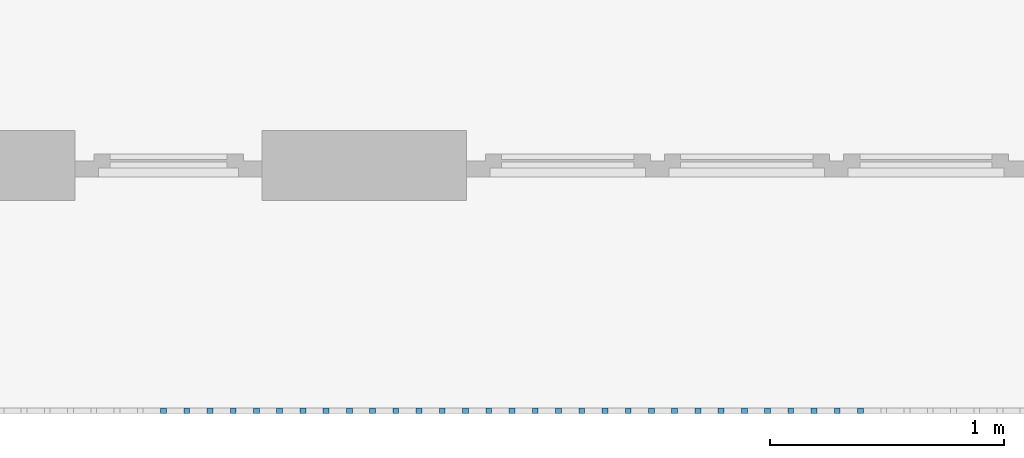
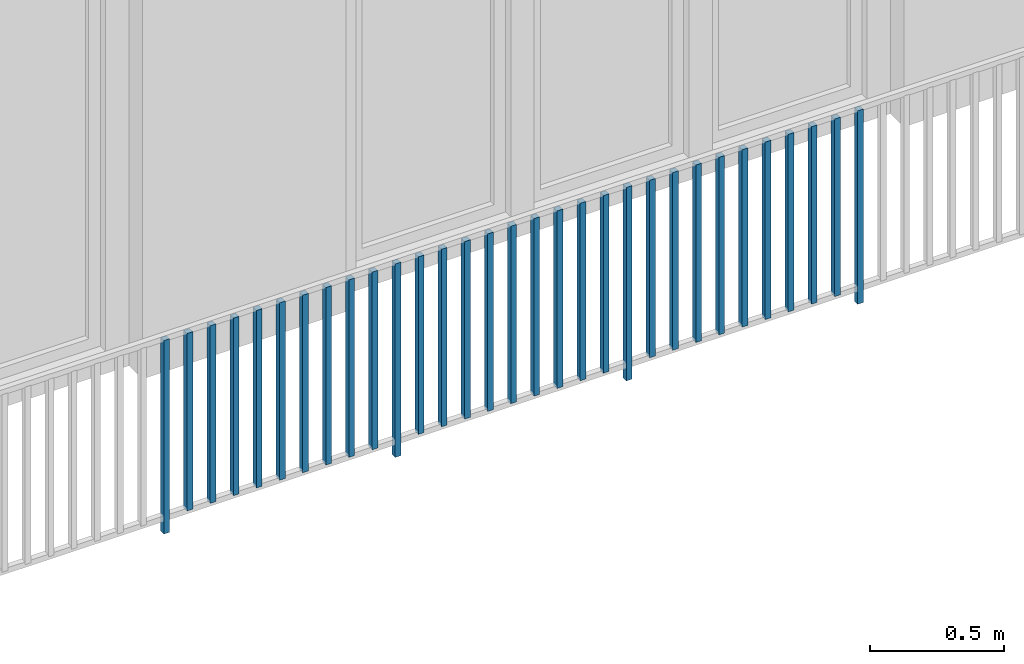
# One storey, part 30 of 48: 31 building element parts, 1 element without a shape of its own.
"""IFC4 building model written with IfcOpenShell, lengths in metres."""

import ifcopenshell
import ifcopenshell.guid

model = None  # the IFC model being written
_history = None  # IfcOwnerHistory: only IFC2X3 demands one
_inside = {}  # id of a spatial element -> (the spatial element, [elements in it])
_under = {}  # id of a project, library or spatial element -> (it, [spatial elements below it])
_declared = {}  # id of a project -> (the project, [libraries it declares])
_typed = {}  # id of a type object -> (the type object, [elements of that type])
_made_of = {}  # id of a material, layer set ... -> (it, [elements and type objects made of it])


def new_model(schema):
    """Start an empty IFC model of exactly this schema.

    Asked for "IFC4X3", IfcOpenShell would pick the latest addendum, in which some entities
    have other attributes; the version numbers below select the first issue.
    IFC2X3 requires an IfcOwnerHistory on every rooted entity: one is made here for all.
    """
    global model, _history
    if schema == "IFC4X3":
        model = ifcopenshell.file(schema_version=(4, 3, 0, 0))
    else:
        model = ifcopenshell.file(schema=schema)
    _inside.clear()
    _under.clear()
    _declared.clear()
    _typed.clear()
    _made_of.clear()
    _history = None
    if model.schema == "IFC2X3":
        org = make("IfcOrganization", Name="unknown")
        user = make(
            "IfcPersonAndOrganization",
            ThePerson=make("IfcPerson", FamilyName="unknown"),
            TheOrganization=org,
        )
        app = make(
            "IfcApplication",
            ApplicationDeveloper=org,
            Version="unknown",
            ApplicationFullName="unknown",
            ApplicationIdentifier="unknown",
        )
        _history = make(
            "IfcOwnerHistory",
            OwningUser=user,
            OwningApplication=app,
            ChangeAction="ADDED",
            CreationDate=0,
        )
    return model


def make(cls, **values):
    """One entity of the class cls with the attributes given. An attribute that is None is left unset."""
    return model.create_entity(
        cls, **{name: value for name, value in values.items() if value is not None}
    )


def entity(cls, *values):
    """Any entity or typed value of the class cls, its attributes in the order of the schema. None: left unset."""
    e = model.create_entity(cls)
    for i, value in enumerate(values):
        if value is not None:
            e[i] = value
    return e


def rooted(cls, **values):
    """An entity with a GlobalId (a new one), such as an element, a storey or a relation."""
    return make(cls, GlobalId=ifcopenshell.guid.new(), OwnerHistory=_history, **values)


def si_unit(unit_type, name, prefix=None):
    """IfcSIUnit, for example si_unit("LENGTHUNIT", "METRE", prefix="MILLI")."""
    return make("IfcSIUnit", UnitType=unit_type, Prefix=prefix, Name=name)


def converted_unit(unit_type, name, factor, base, dimensions=None, offset=None):
    """IfcConversionBasedUnit, such as the inch: factor (a typed value) times the base unit."""
    return make(
        "IfcConversionBasedUnit"
        if offset is None
        else "IfcConversionBasedUnitWithOffset",
        ConversionOffset=offset,
        Dimensions=None
        if dimensions is None
        else entity("IfcDimensionalExponents", *dimensions),
        UnitType=unit_type,
        Name=name,
        ConversionFactor=make(
            "IfcMeasureWithUnit", ValueComponent=factor, UnitComponent=base
        ),
    )


def derived_unit(unit_type, elements):
    """IfcDerivedUnit: a product of units, each with its exponent."""
    return make(
        "IfcDerivedUnit",
        Elements=[
            make("IfcDerivedUnitElement", Unit=unit, Exponent=power)
            for unit, power in elements
        ],
        UnitType=unit_type,
    )


def assignment(units):
    """IfcUnitAssignment: the units of a project."""
    return None if units is None else make("IfcUnitAssignment", Units=units)


def point(xyz):
    """IfcCartesianPoint."""
    return None if xyz is None else make("IfcCartesianPoint", Coordinates=xyz)


def direction(xyz):
    """IfcDirection."""
    return None if xyz is None else make("IfcDirection", DirectionRatios=xyz)


def frame(location, z_axis=None, x_axis=None):
    """IfcAxis2Placement3D, a coordinate frame: its origin and axes. An axis left out is left unset."""
    return make(
        "IfcAxis2Placement3D",
        Location=point(location),
        Axis=direction(z_axis),
        RefDirection=direction(x_axis),
    )


def origin_with_axes():
    """The frame at (0, 0, 0) with the z axis (0, 0, 1) and the x axis (1, 0, 0) written out."""
    return frame((0.0, 0.0, 0.0), z_axis=(0.0, 0.0, 1.0), x_axis=(1.0, 0.0, 0.0))


def place(relative_to, where):
    """IfcLocalPlacement: puts the frame where relative to a parent placement (None: the world)."""
    return make(
        "IfcLocalPlacement", PlacementRelTo=relative_to, RelativePlacement=where
    )


def context(
    kind, dimensions, precision=None, world=None, true_north=None, identifier=None
):
    """IfcGeometricRepresentationContext, for example the 3D "Model" context."""
    return make(
        "IfcGeometricRepresentationContext",
        ContextIdentifier=identifier,
        ContextType=kind,
        CoordinateSpaceDimension=dimensions,
        Precision=precision,
        WorldCoordinateSystem=world,
        TrueNorth=true_north,
    )


def subcontext(parent, identifier, kind, view, scale=None):
    """IfcGeometricRepresentationSubContext, for example "Body" below "Model"."""
    return make(
        "IfcGeometricRepresentationSubContext",
        ContextIdentifier=identifier,
        ContextType=kind,
        ParentContext=parent,
        TargetScale=scale,
        TargetView=view,
    )


def project(units=None, contexts=None):
    """IfcProject with its units and contexts."""
    return rooted(
        "IfcProject",
        Name="project",
        RepresentationContexts=contexts,
        UnitsInContext=assignment(units),
    )


def spatial(cls, under=None, at=None, **own):
    """A site, building, storey or space (cls), placed at a placement, below another one or the project."""
    s = rooted(cls, ObjectPlacement=at, **own)
    if under is not None:
        _under.setdefault(under.id(), (under, []))[1].append(s)
    return s


def point_list(points):
    """IfcCartesianPointList2D or 3D."""
    cls = (
        "IfcCartesianPointList2D" if len(points[0]) == 2 else "IfcCartesianPointList3D"
    )
    return make(cls, CoordList=points)


def polygons(points, faces, closed=None, point_numbers=None):
    """IfcPolygonalFaceSet: a face is its outer loop, then its inner loops; points numbered from 1."""
    made = []
    for loops in faces:
        if len(loops) == 1:
            made.append(make("IfcIndexedPolygonalFace", CoordIndex=loops[0]))
        else:
            made.append(
                make(
                    "IfcIndexedPolygonalFaceWithVoids",
                    CoordIndex=loops[0],
                    InnerCoordIndices=loops[1:],
                )
            )
    return make(
        "IfcPolygonalFaceSet",
        Coordinates=point_list(points),
        Closed=closed,
        Faces=made,
        PnIndex=point_numbers,
    )


def shape(context_of_items, identifier, shape_type, items):
    """IfcShapeRepresentation: the items that make up one representation, for example the "Body"."""
    return make(
        "IfcShapeRepresentation",
        ContextOfItems=context_of_items,
        RepresentationIdentifier=identifier,
        RepresentationType=shape_type,
        Items=items,
    )


def material(Name=None, Category=None):
    """IfcMaterial."""
    return make("IfcMaterial", Name=Name, Category=Category)


def made_of(thing, what):
    """Note that an element or type object is made of a material, layer set ...; save() writes the relation."""
    if what is not None:
        _made_of.setdefault(what.id(), (what, []))[1].append(thing)
    return thing


def type_object(cls, material=None, **own):
    """A type object (cls), such as IfcWallType, which elements share."""
    return made_of(rooted(cls, **own), material)


def element(
    cls,
    number,
    at=None,
    inside=None,
    cuts=None,
    type_object=None,
    material=None,
    context=None,
    identifier="Body",
    shape_type=None,
    held_by="IfcProductDefinitionShape",
    body=None,
    shapes=None,
    **own,
):
    """One element of the class cls, such as IfcWall. Its Tag is "e" and its number.

    at: its placement. inside: the storey or other place that contains it. cuts: it is an
    opening in that element (IfcRelVoidsElement). A single representation is given by context,
    identifier, shape_type and body (its items); several are given by shapes. held_by: the class
    of the entity that holds the representations. save() writes the other relations.
    """
    e = rooted(cls, Tag="e%d" % number, ObjectPlacement=at, **own)
    if body is not None:
        shapes = [shape(context, identifier, shape_type, body)]
    if shapes is not None:
        e.Representation = make(held_by, Representations=shapes)
    if inside is not None:
        _inside.setdefault(inside.id(), (inside, []))[1].append(e)
    if cuts is not None:
        rooted(
            "IfcRelVoidsElement", RelatingBuildingElement=cuts, RelatedOpeningElement=e
        )
    if type_object is not None:
        _typed.setdefault(type_object.id(), (type_object, []))[1].append(e)
    return made_of(e, material)


def aggregate(whole, parts):
    """IfcRelAggregates: a whole, such as a stair, and the parts it consists of."""
    return rooted("IfcRelAggregates", RelatingObject=whole, RelatedObjects=parts)


def save(model, path):
    """Write the relations noted so far, then the file.

    IfcRelAggregates (storeys below a building ...), IfcRelContainedInSpatialStructure (elements
    in a storey), IfcRelDefinesByType, IfcRelAssociatesMaterial and IfcRelDeclares: one each for
    every whole, place, type object, material and project.
    """
    for whole, parts in _under.values():
        aggregate(whole, parts)
    for where, things in _inside.values():
        rooted(
            "IfcRelContainedInSpatialStructure",
            RelatedElements=things,
            RelatingStructure=where,
        )
    for kind, things in _typed.values():
        rooted("IfcRelDefinesByType", RelatedObjects=things, RelatingType=kind)
    for what, things in _made_of.values():
        rooted("IfcRelAssociatesMaterial", RelatedObjects=things, RelatingMaterial=what)
    for by, libraries in _declared.values():
        rooted("IfcRelDeclares", RelatingContext=by, RelatedDefinitions=libraries)
    model.write(path)


model = new_model("IFC4")

# Units and contexts
model_context = context("Model", 3, precision=1e-05, world=origin_with_axes(), true_north=direction((0.0, 1.0)))
body_context = subcontext(model_context, "Body", "Model", "MODEL_VIEW")
ifc_project = project(units=[si_unit("LENGTHUNIT", "METRE"), si_unit("AREAUNIT", "SQUARE_METRE"), si_unit("VOLUMEUNIT", "CUBIC_METRE"), converted_unit("PLANEANGLEUNIT", "DEGREE", entity("IfcPlaneAngleMeasure", 0.0174532925199), si_unit("PLANEANGLEUNIT", "RADIAN"), dimensions=[0, 0, 0, 0, 0, 0, 0]), converted_unit("TIMEUNIT", "Year", entity("IfcTimeMeasure", 31556926.0), si_unit("TIMEUNIT", "SECOND"), dimensions=[0, 0, 1, 0, 0, 0, 0]), si_unit("MASSUNIT", "GRAM", prefix="KILO"), si_unit("THERMODYNAMICTEMPERATUREUNIT", "DEGREE_CELSIUS"), si_unit("LUMINOUSINTENSITYUNIT", "LUMEN"), si_unit("ENERGYUNIT", "JOULE", prefix="MEGA"), derived_unit("THERMALCONDUCTANCEUNIT", [(si_unit("POWERUNIT", "WATT"), 1), (si_unit("LENGTHUNIT", "METRE"), -1), (si_unit("THERMODYNAMICTEMPERATUREUNIT", "KELVIN"), -1)]), derived_unit("SPECIFICHEATCAPACITYUNIT", [(si_unit("ENERGYUNIT", "JOULE"), 1), (si_unit("MASSUNIT", "GRAM", prefix="KILO"), -1), (si_unit("THERMODYNAMICTEMPERATUREUNIT", "KELVIN"), -1)]), derived_unit("MASSDENSITYUNIT", [(si_unit("MASSUNIT", "GRAM", prefix="KILO"), 1), (si_unit("VOLUMEUNIT", "CUBIC_METRE"), -1)])], contexts=[model_context])

# Site, building, storey
site_placement = place(None, origin_with_axes())
site = spatial("IfcSite", under=ifc_project, at=site_placement, CompositionType="ELEMENT")
building_placement = place(site_placement, origin_with_axes())
building = spatial("IfcBuilding", under=site, at=building_placement, CompositionType="ELEMENT")
storey_placement = place(building_placement, frame((0.0, 0.0, 3.4), z_axis=(0.0, 0.0, 1.0), x_axis=(1.0, 0.0, 0.0)))
storey = spatial("IfcBuildingStorey", under=building, at=storey_placement, Name="1. Geschoss", CompositionType="ELEMENT", Elevation=3.4)

# Railing, building element parts
railing_type = type_object("IfcRailingType", PredefinedType="NOTDEFINED")
railing_placement = place(storey_placement, frame((10.2378006196, 9.82118776896, 0.0), z_axis=(0.0, 0.0, 1.0), x_axis=(1.0, 0.0, 0.0)))
railing = element("IfcRailing", 1, at=railing_placement, inside=storey, type_object=railing_type, PredefinedType="NOTDEFINED")
ifc_material = material()
building_element_part_1_placement = place(railing_placement, origin_with_axes())
building_element_part_1 = element("IfcBuildingElementPart", 2, at=building_element_part_1_placement, material=ifc_material, PredefinedType="NOTDEFINED", context=body_context, shape_type="Tessellation", body=[
    polygons([(-9.93532608696, -20.6625, 0.0), (-9.93532608696, -20.6375, 0.0), (-9.93532608696, -20.6375, 0.88), (-9.93532608696, -20.6625, 0.88), (-9.96032608696, -20.6625, 0.0), (-9.96032608696, -20.6375, 0.0), (-9.96032608696, -20.6375, 0.88), (-9.96032608696, -20.6625, 0.88)], [[[1, 2, 3, 4]], [[1, 5, 6, 2]], [[2, 6, 7, 3]], [[4, 3, 7, 8]], [[5, 1, 4, 8]], [[6, 5, 8, 7]]], closed=True),
])
building_element_part_2_placement = place(railing_placement, origin_with_axes())
building_element_part_2 = element("IfcBuildingElementPart", 3, at=building_element_part_2_placement, material=ifc_material, PredefinedType="NOTDEFINED", context=body_context, shape_type="Tessellation", body=[
    polygons([(-9.83584782609, -20.6625, 0.07), (-9.83584782609, -20.6375, 0.07), (-9.83584782609, -20.6375, 0.8775), (-9.83584782609, -20.6625, 0.8775), (-9.86084782609, -20.6625, 0.07), (-9.86084782609, -20.6375, 0.07), (-9.86084782609, -20.6375, 0.8775), (-9.86084782609, -20.6625, 0.8775)], [[[1, 2, 3, 4]], [[1, 5, 6, 2]], [[2, 6, 7, 3]], [[4, 3, 7, 8]], [[5, 1, 4, 8]], [[6, 5, 8, 7]]], closed=True),
])
building_element_part_3_placement = place(railing_placement, origin_with_axes())
building_element_part_3 = element("IfcBuildingElementPart", 4, at=building_element_part_3_placement, material=ifc_material, PredefinedType="NOTDEFINED", context=body_context, shape_type="Tessellation", body=[
    polygons([(-9.73636956522, -20.6625, 0.07), (-9.73636956522, -20.6375, 0.07), (-9.73636956522, -20.6375, 0.8775), (-9.73636956522, -20.6625, 0.8775), (-9.76136956522, -20.6625, 0.07), (-9.76136956522, -20.6375, 0.07), (-9.76136956522, -20.6375, 0.8775), (-9.76136956522, -20.6625, 0.8775)], [[[1, 2, 3, 4]], [[1, 5, 6, 2]], [[2, 6, 7, 3]], [[4, 3, 7, 8]], [[5, 1, 4, 8]], [[6, 5, 8, 7]]], closed=True),
])
building_element_part_4_placement = place(railing_placement, origin_with_axes())
building_element_part_4 = element("IfcBuildingElementPart", 5, at=building_element_part_4_placement, material=ifc_material, PredefinedType="NOTDEFINED", context=body_context, shape_type="Tessellation", body=[
    polygons([(-9.63689130435, -20.6625, 0.07), (-9.63689130435, -20.6375, 0.07), (-9.63689130435, -20.6375, 0.8775), (-9.63689130435, -20.6625, 0.8775), (-9.66189130435, -20.6625, 0.07), (-9.66189130435, -20.6375, 0.07), (-9.66189130435, -20.6375, 0.8775), (-9.66189130435, -20.6625, 0.8775)], [[[1, 2, 3, 4]], [[1, 5, 6, 2]], [[2, 6, 7, 3]], [[4, 3, 7, 8]], [[5, 1, 4, 8]], [[6, 5, 8, 7]]], closed=True),
])
building_element_part_5_placement = place(railing_placement, origin_with_axes())
building_element_part_5 = element("IfcBuildingElementPart", 6, at=building_element_part_5_placement, material=ifc_material, PredefinedType="NOTDEFINED", context=body_context, shape_type="Tessellation", body=[
    polygons([(-9.53741304348, -20.6625, 0.07), (-9.53741304348, -20.6375, 0.07), (-9.53741304348, -20.6375, 0.8775), (-9.53741304348, -20.6625, 0.8775), (-9.56241304348, -20.6625, 0.07), (-9.56241304348, -20.6375, 0.07), (-9.56241304348, -20.6375, 0.8775), (-9.56241304348, -20.6625, 0.8775)], [[[1, 2, 3, 4]], [[1, 5, 6, 2]], [[2, 6, 7, 3]], [[4, 3, 7, 8]], [[5, 1, 4, 8]], [[6, 5, 8, 7]]], closed=True),
])
building_element_part_6_placement = place(railing_placement, origin_with_axes())
building_element_part_6 = element("IfcBuildingElementPart", 7, at=building_element_part_6_placement, material=ifc_material, PredefinedType="NOTDEFINED", context=body_context, shape_type="Tessellation", body=[
    polygons([(-9.43793478261, -20.6625, 0.07), (-9.43793478261, -20.6375, 0.07), (-9.43793478261, -20.6375, 0.8775), (-9.43793478261, -20.6625, 0.8775), (-9.46293478261, -20.6625, 0.07), (-9.46293478261, -20.6375, 0.07), (-9.46293478261, -20.6375, 0.8775), (-9.46293478261, -20.6625, 0.8775)], [[[1, 2, 3, 4]], [[1, 5, 6, 2]], [[2, 6, 7, 3]], [[4, 3, 7, 8]], [[5, 1, 4, 8]], [[6, 5, 8, 7]]], closed=True),
])
building_element_part_7_placement = place(railing_placement, origin_with_axes())
building_element_part_7 = element("IfcBuildingElementPart", 8, at=building_element_part_7_placement, material=ifc_material, PredefinedType="NOTDEFINED", context=body_context, shape_type="Tessellation", body=[
    polygons([(-9.33845652174, -20.6625, 0.07), (-9.33845652174, -20.6375, 0.07), (-9.33845652174, -20.6375, 0.8775), (-9.33845652174, -20.6625, 0.8775), (-9.36345652174, -20.6625, 0.07), (-9.36345652174, -20.6375, 0.07), (-9.36345652174, -20.6375, 0.8775), (-9.36345652174, -20.6625, 0.8775)], [[[1, 2, 3, 4]], [[1, 5, 6, 2]], [[2, 6, 7, 3]], [[4, 3, 7, 8]], [[5, 1, 4, 8]], [[6, 5, 8, 7]]], closed=True),
])
building_element_part_8_placement = place(railing_placement, origin_with_axes())
building_element_part_8 = element("IfcBuildingElementPart", 9, at=building_element_part_8_placement, material=ifc_material, PredefinedType="NOTDEFINED", context=body_context, shape_type="Tessellation", body=[
    polygons([(-9.23897826087, -20.6625, 0.07), (-9.23897826087, -20.6375, 0.07), (-9.23897826087, -20.6375, 0.8775), (-9.23897826087, -20.6625, 0.8775), (-9.26397826087, -20.6625, 0.07), (-9.26397826087, -20.6375, 0.07), (-9.26397826087, -20.6375, 0.8775), (-9.26397826087, -20.6625, 0.8775)], [[[1, 2, 3, 4]], [[1, 5, 6, 2]], [[2, 6, 7, 3]], [[4, 3, 7, 8]], [[5, 1, 4, 8]], [[6, 5, 8, 7]]], closed=True),
])
building_element_part_9_placement = place(railing_placement, origin_with_axes())
building_element_part_9 = element("IfcBuildingElementPart", 10, at=building_element_part_9_placement, material=ifc_material, PredefinedType="NOTDEFINED", context=body_context, shape_type="Tessellation", body=[
    polygons([(-9.1395, -20.6625, 0.07), (-9.1395, -20.6375, 0.07), (-9.1395, -20.6375, 0.8775), (-9.1395, -20.6625, 0.8775), (-9.1645, -20.6625, 0.07), (-9.1645, -20.6375, 0.07), (-9.1645, -20.6375, 0.8775), (-9.1645, -20.6625, 0.8775)], [[[1, 2, 3, 4]], [[1, 5, 6, 2]], [[2, 6, 7, 3]], [[4, 3, 7, 8]], [[5, 1, 4, 8]], [[6, 5, 8, 7]]], closed=True),
])
building_element_part_10_placement = place(railing_placement, origin_with_axes())
building_element_part_10 = element("IfcBuildingElementPart", 11, at=building_element_part_10_placement, material=ifc_material, PredefinedType="NOTDEFINED", context=body_context, shape_type="Tessellation", body=[
    polygons([(-9.04002173913, -20.6625, 0.07), (-9.04002173913, -20.6375, 0.07), (-9.04002173913, -20.6375, 0.8775), (-9.04002173913, -20.6625, 0.8775), (-9.06502173913, -20.6625, 0.07), (-9.06502173913, -20.6375, 0.07), (-9.06502173913, -20.6375, 0.8775), (-9.06502173913, -20.6625, 0.8775)], [[[1, 2, 3, 4]], [[1, 5, 6, 2]], [[2, 6, 7, 3]], [[4, 3, 7, 8]], [[5, 1, 4, 8]], [[6, 5, 8, 7]]], closed=True),
])
building_element_part_11_placement = place(railing_placement, origin_with_axes())
building_element_part_11 = element("IfcBuildingElementPart", 12, at=building_element_part_11_placement, material=ifc_material, PredefinedType="NOTDEFINED", context=body_context, shape_type="Tessellation", body=[
    polygons([(-8.94054347826, -20.6625, 0.0), (-8.94054347826, -20.6375, 0.0), (-8.94054347826, -20.6375, 0.88), (-8.94054347826, -20.6625, 0.88), (-8.96554347826, -20.6625, 0.0), (-8.96554347826, -20.6375, 0.0), (-8.96554347826, -20.6375, 0.88), (-8.96554347826, -20.6625, 0.88)], [[[1, 2, 3, 4]], [[1, 5, 6, 2]], [[2, 6, 7, 3]], [[4, 3, 7, 8]], [[5, 1, 4, 8]], [[6, 5, 8, 7]]], closed=True),
])
building_element_part_12_placement = place(railing_placement, origin_with_axes())
building_element_part_12 = element("IfcBuildingElementPart", 13, at=building_element_part_12_placement, material=ifc_material, PredefinedType="NOTDEFINED", context=body_context, shape_type="Tessellation", body=[
    polygons([(-8.84106521739, -20.6625, 0.07), (-8.84106521739, -20.6375, 0.07), (-8.84106521739, -20.6375, 0.8775), (-8.84106521739, -20.6625, 0.8775), (-8.86606521739, -20.6625, 0.07), (-8.86606521739, -20.6375, 0.07), (-8.86606521739, -20.6375, 0.8775), (-8.86606521739, -20.6625, 0.8775)], [[[1, 2, 3, 4]], [[1, 5, 6, 2]], [[2, 6, 7, 3]], [[4, 3, 7, 8]], [[5, 1, 4, 8]], [[6, 5, 8, 7]]], closed=True),
])
building_element_part_13_placement = place(railing_placement, origin_with_axes())
building_element_part_13 = element("IfcBuildingElementPart", 14, at=building_element_part_13_placement, material=ifc_material, PredefinedType="NOTDEFINED", context=body_context, shape_type="Tessellation", body=[
    polygons([(-8.74158695652, -20.6625, 0.07), (-8.74158695652, -20.6375, 0.07), (-8.74158695652, -20.6375, 0.8775), (-8.74158695652, -20.6625, 0.8775), (-8.76658695652, -20.6625, 0.07), (-8.76658695652, -20.6375, 0.07), (-8.76658695652, -20.6375, 0.8775), (-8.76658695652, -20.6625, 0.8775)], [[[1, 2, 3, 4]], [[1, 5, 6, 2]], [[2, 6, 7, 3]], [[4, 3, 7, 8]], [[5, 1, 4, 8]], [[6, 5, 8, 7]]], closed=True),
])
building_element_part_14_placement = place(railing_placement, origin_with_axes())
building_element_part_14 = element("IfcBuildingElementPart", 15, at=building_element_part_14_placement, material=ifc_material, PredefinedType="NOTDEFINED", context=body_context, shape_type="Tessellation", body=[
    polygons([(-8.64210869565, -20.6625, 0.07), (-8.64210869565, -20.6375, 0.07), (-8.64210869565, -20.6375, 0.8775), (-8.64210869565, -20.6625, 0.8775), (-8.66710869565, -20.6625, 0.07), (-8.66710869565, -20.6375, 0.07), (-8.66710869565, -20.6375, 0.8775), (-8.66710869565, -20.6625, 0.8775)], [[[1, 2, 3, 4]], [[1, 5, 6, 2]], [[2, 6, 7, 3]], [[4, 3, 7, 8]], [[5, 1, 4, 8]], [[6, 5, 8, 7]]], closed=True),
])
building_element_part_15_placement = place(railing_placement, origin_with_axes())
building_element_part_15 = element("IfcBuildingElementPart", 16, at=building_element_part_15_placement, material=ifc_material, PredefinedType="NOTDEFINED", context=body_context, shape_type="Tessellation", body=[
    polygons([(-8.54263043478, -20.6625, 0.07), (-8.54263043478, -20.6375, 0.07), (-8.54263043478, -20.6375, 0.8775), (-8.54263043478, -20.6625, 0.8775), (-8.56763043478, -20.6625, 0.07), (-8.56763043478, -20.6375, 0.07), (-8.56763043478, -20.6375, 0.8775), (-8.56763043478, -20.6625, 0.8775)], [[[1, 2, 3, 4]], [[1, 5, 6, 2]], [[2, 6, 7, 3]], [[4, 3, 7, 8]], [[5, 1, 4, 8]], [[6, 5, 8, 7]]], closed=True),
])
building_element_part_16_placement = place(railing_placement, origin_with_axes())
building_element_part_16 = element("IfcBuildingElementPart", 17, at=building_element_part_16_placement, material=ifc_material, PredefinedType="NOTDEFINED", context=body_context, shape_type="Tessellation", body=[
    polygons([(-8.44315217391, -20.6625, 0.07), (-8.44315217391, -20.6375, 0.07), (-8.44315217391, -20.6375, 0.8775), (-8.44315217391, -20.6625, 0.8775), (-8.46815217391, -20.6625, 0.07), (-8.46815217391, -20.6375, 0.07), (-8.46815217391, -20.6375, 0.8775), (-8.46815217391, -20.6625, 0.8775)], [[[1, 2, 3, 4]], [[1, 5, 6, 2]], [[2, 6, 7, 3]], [[4, 3, 7, 8]], [[5, 1, 4, 8]], [[6, 5, 8, 7]]], closed=True),
])
building_element_part_17_placement = place(railing_placement, origin_with_axes())
building_element_part_17 = element("IfcBuildingElementPart", 18, at=building_element_part_17_placement, material=ifc_material, PredefinedType="NOTDEFINED", context=body_context, shape_type="Tessellation", body=[
    polygons([(-8.34367391304, -20.6625, 0.07), (-8.34367391304, -20.6375, 0.07), (-8.34367391304, -20.6375, 0.8775), (-8.34367391304, -20.6625, 0.8775), (-8.36867391304, -20.6625, 0.07), (-8.36867391304, -20.6375, 0.07), (-8.36867391304, -20.6375, 0.8775), (-8.36867391304, -20.6625, 0.8775)], [[[1, 2, 3, 4]], [[1, 5, 6, 2]], [[2, 6, 7, 3]], [[4, 3, 7, 8]], [[5, 1, 4, 8]], [[6, 5, 8, 7]]], closed=True),
])
building_element_part_18_placement = place(railing_placement, origin_with_axes())
building_element_part_18 = element("IfcBuildingElementPart", 19, at=building_element_part_18_placement, material=ifc_material, PredefinedType="NOTDEFINED", context=body_context, shape_type="Tessellation", body=[
    polygons([(-8.24419565217, -20.6625, 0.07), (-8.24419565217, -20.6375, 0.07), (-8.24419565217, -20.6375, 0.8775), (-8.24419565217, -20.6625, 0.8775), (-8.26919565217, -20.6625, 0.07), (-8.26919565217, -20.6375, 0.07), (-8.26919565217, -20.6375, 0.8775), (-8.26919565217, -20.6625, 0.8775)], [[[1, 2, 3, 4]], [[1, 5, 6, 2]], [[2, 6, 7, 3]], [[4, 3, 7, 8]], [[5, 1, 4, 8]], [[6, 5, 8, 7]]], closed=True),
])
building_element_part_19_placement = place(railing_placement, origin_with_axes())
building_element_part_19 = element("IfcBuildingElementPart", 20, at=building_element_part_19_placement, material=ifc_material, PredefinedType="NOTDEFINED", context=body_context, shape_type="Tessellation", body=[
    polygons([(-8.1447173913, -20.6625, 0.07), (-8.1447173913, -20.6375, 0.07), (-8.1447173913, -20.6375, 0.8775), (-8.1447173913, -20.6625, 0.8775), (-8.1697173913, -20.6625, 0.07), (-8.1697173913, -20.6375, 0.07), (-8.1697173913, -20.6375, 0.8775), (-8.1697173913, -20.6625, 0.8775)], [[[1, 2, 3, 4]], [[1, 5, 6, 2]], [[2, 6, 7, 3]], [[4, 3, 7, 8]], [[5, 1, 4, 8]], [[6, 5, 8, 7]]], closed=True),
])
building_element_part_20_placement = place(railing_placement, origin_with_axes())
building_element_part_20 = element("IfcBuildingElementPart", 21, at=building_element_part_20_placement, material=ifc_material, PredefinedType="NOTDEFINED", context=body_context, shape_type="Tessellation", body=[
    polygons([(-8.04523913043, -20.6625, 0.07), (-8.04523913043, -20.6375, 0.07), (-8.04523913043, -20.6375, 0.8775), (-8.04523913043, -20.6625, 0.8775), (-8.07023913043, -20.6625, 0.07), (-8.07023913043, -20.6375, 0.07), (-8.07023913043, -20.6375, 0.8775), (-8.07023913043, -20.6625, 0.8775)], [[[1, 2, 3, 4]], [[1, 5, 6, 2]], [[2, 6, 7, 3]], [[4, 3, 7, 8]], [[5, 1, 4, 8]], [[6, 5, 8, 7]]], closed=True),
])
building_element_part_21_placement = place(railing_placement, origin_with_axes())
building_element_part_21 = element("IfcBuildingElementPart", 22, at=building_element_part_21_placement, material=ifc_material, PredefinedType="NOTDEFINED", context=body_context, shape_type="Tessellation", body=[
    polygons([(-7.94576086957, -20.6625, 0.0), (-7.94576086957, -20.6375, 0.0), (-7.94576086957, -20.6375, 0.88), (-7.94576086957, -20.6625, 0.88), (-7.97076086957, -20.6625, 0.0), (-7.97076086957, -20.6375, 0.0), (-7.97076086957, -20.6375, 0.88), (-7.97076086957, -20.6625, 0.88)], [[[1, 2, 3, 4]], [[1, 5, 6, 2]], [[2, 6, 7, 3]], [[4, 3, 7, 8]], [[5, 1, 4, 8]], [[6, 5, 8, 7]]], closed=True),
])
building_element_part_22_placement = place(railing_placement, origin_with_axes())
building_element_part_22 = element("IfcBuildingElementPart", 23, at=building_element_part_22_placement, material=ifc_material, PredefinedType="NOTDEFINED", context=body_context, shape_type="Tessellation", body=[
    polygons([(-7.8462826087, -20.6625, 0.07), (-7.8462826087, -20.6375, 0.07), (-7.8462826087, -20.6375, 0.8775), (-7.8462826087, -20.6625, 0.8775), (-7.8712826087, -20.6625, 0.07), (-7.8712826087, -20.6375, 0.07), (-7.8712826087, -20.6375, 0.8775), (-7.8712826087, -20.6625, 0.8775)], [[[1, 2, 3, 4]], [[1, 5, 6, 2]], [[2, 6, 7, 3]], [[4, 3, 7, 8]], [[5, 1, 4, 8]], [[6, 5, 8, 7]]], closed=True),
])
building_element_part_23_placement = place(railing_placement, origin_with_axes())
building_element_part_23 = element("IfcBuildingElementPart", 24, at=building_element_part_23_placement, material=ifc_material, PredefinedType="NOTDEFINED", context=body_context, shape_type="Tessellation", body=[
    polygons([(-7.74680434783, -20.6625, 0.07), (-7.74680434783, -20.6375, 0.07), (-7.74680434783, -20.6375, 0.8775), (-7.74680434783, -20.6625, 0.8775), (-7.77180434783, -20.6625, 0.07), (-7.77180434783, -20.6375, 0.07), (-7.77180434783, -20.6375, 0.8775), (-7.77180434783, -20.6625, 0.8775)], [[[1, 2, 3, 4]], [[1, 5, 6, 2]], [[2, 6, 7, 3]], [[4, 3, 7, 8]], [[5, 1, 4, 8]], [[6, 5, 8, 7]]], closed=True),
])
building_element_part_24_placement = place(railing_placement, origin_with_axes())
building_element_part_24 = element("IfcBuildingElementPart", 25, at=building_element_part_24_placement, material=ifc_material, PredefinedType="NOTDEFINED", context=body_context, shape_type="Tessellation", body=[
    polygons([(-7.64732608696, -20.6625, 0.07), (-7.64732608696, -20.6375, 0.07), (-7.64732608696, -20.6375, 0.8775), (-7.64732608696, -20.6625, 0.8775), (-7.67232608696, -20.6625, 0.07), (-7.67232608696, -20.6375, 0.07), (-7.67232608696, -20.6375, 0.8775), (-7.67232608696, -20.6625, 0.8775)], [[[1, 2, 3, 4]], [[1, 5, 6, 2]], [[2, 6, 7, 3]], [[4, 3, 7, 8]], [[5, 1, 4, 8]], [[6, 5, 8, 7]]], closed=True),
])
building_element_part_25_placement = place(railing_placement, origin_with_axes())
building_element_part_25 = element("IfcBuildingElementPart", 26, at=building_element_part_25_placement, material=ifc_material, PredefinedType="NOTDEFINED", context=body_context, shape_type="Tessellation", body=[
    polygons([(-7.54784782609, -20.6625, 0.07), (-7.54784782609, -20.6375, 0.07), (-7.54784782609, -20.6375, 0.8775), (-7.54784782609, -20.6625, 0.8775), (-7.57284782609, -20.6625, 0.07), (-7.57284782609, -20.6375, 0.07), (-7.57284782609, -20.6375, 0.8775), (-7.57284782609, -20.6625, 0.8775)], [[[1, 2, 3, 4]], [[1, 5, 6, 2]], [[2, 6, 7, 3]], [[4, 3, 7, 8]], [[5, 1, 4, 8]], [[6, 5, 8, 7]]], closed=True),
])
building_element_part_26_placement = place(railing_placement, origin_with_axes())
building_element_part_26 = element("IfcBuildingElementPart", 27, at=building_element_part_26_placement, material=ifc_material, PredefinedType="NOTDEFINED", context=body_context, shape_type="Tessellation", body=[
    polygons([(-7.44836956522, -20.6625, 0.07), (-7.44836956522, -20.6375, 0.07), (-7.44836956522, -20.6375, 0.8775), (-7.44836956522, -20.6625, 0.8775), (-7.47336956522, -20.6625, 0.07), (-7.47336956522, -20.6375, 0.07), (-7.47336956522, -20.6375, 0.8775), (-7.47336956522, -20.6625, 0.8775)], [[[1, 2, 3, 4]], [[1, 5, 6, 2]], [[2, 6, 7, 3]], [[4, 3, 7, 8]], [[5, 1, 4, 8]], [[6, 5, 8, 7]]], closed=True),
])
building_element_part_27_placement = place(railing_placement, origin_with_axes())
building_element_part_27 = element("IfcBuildingElementPart", 28, at=building_element_part_27_placement, material=ifc_material, PredefinedType="NOTDEFINED", context=body_context, shape_type="Tessellation", body=[
    polygons([(-7.34889130435, -20.6625, 0.07), (-7.34889130435, -20.6375, 0.07), (-7.34889130435, -20.6375, 0.8775), (-7.34889130435, -20.6625, 0.8775), (-7.37389130435, -20.6625, 0.07), (-7.37389130435, -20.6375, 0.07), (-7.37389130435, -20.6375, 0.8775), (-7.37389130435, -20.6625, 0.8775)], [[[1, 2, 3, 4]], [[1, 5, 6, 2]], [[2, 6, 7, 3]], [[4, 3, 7, 8]], [[5, 1, 4, 8]], [[6, 5, 8, 7]]], closed=True),
])
building_element_part_28_placement = place(railing_placement, origin_with_axes())
building_element_part_28 = element("IfcBuildingElementPart", 29, at=building_element_part_28_placement, material=ifc_material, PredefinedType="NOTDEFINED", context=body_context, shape_type="Tessellation", body=[
    polygons([(-7.24941304348, -20.6625, 0.07), (-7.24941304348, -20.6375, 0.07), (-7.24941304348, -20.6375, 0.8775), (-7.24941304348, -20.6625, 0.8775), (-7.27441304348, -20.6625, 0.07), (-7.27441304348, -20.6375, 0.07), (-7.27441304348, -20.6375, 0.8775), (-7.27441304348, -20.6625, 0.8775)], [[[1, 2, 3, 4]], [[1, 5, 6, 2]], [[2, 6, 7, 3]], [[4, 3, 7, 8]], [[5, 1, 4, 8]], [[6, 5, 8, 7]]], closed=True),
])
building_element_part_29_placement = place(railing_placement, origin_with_axes())
building_element_part_29 = element("IfcBuildingElementPart", 30, at=building_element_part_29_placement, material=ifc_material, PredefinedType="NOTDEFINED", context=body_context, shape_type="Tessellation", body=[
    polygons([(-7.14993478261, -20.6625, 0.07), (-7.14993478261, -20.6375, 0.07), (-7.14993478261, -20.6375, 0.8775), (-7.14993478261, -20.6625, 0.8775), (-7.17493478261, -20.6625, 0.07), (-7.17493478261, -20.6375, 0.07), (-7.17493478261, -20.6375, 0.8775), (-7.17493478261, -20.6625, 0.8775)], [[[1, 2, 3, 4]], [[1, 5, 6, 2]], [[2, 6, 7, 3]], [[4, 3, 7, 8]], [[5, 1, 4, 8]], [[6, 5, 8, 7]]], closed=True),
])
building_element_part_30_placement = place(railing_placement, origin_with_axes())
building_element_part_30 = element("IfcBuildingElementPart", 31, at=building_element_part_30_placement, material=ifc_material, PredefinedType="NOTDEFINED", context=body_context, shape_type="Tessellation", body=[
    polygons([(-7.05045652174, -20.6625, 0.07), (-7.05045652174, -20.6375, 0.07), (-7.05045652174, -20.6375, 0.8775), (-7.05045652174, -20.6625, 0.8775), (-7.07545652174, -20.6625, 0.07), (-7.07545652174, -20.6375, 0.07), (-7.07545652174, -20.6375, 0.8775), (-7.07545652174, -20.6625, 0.8775)], [[[1, 2, 3, 4]], [[1, 5, 6, 2]], [[2, 6, 7, 3]], [[4, 3, 7, 8]], [[5, 1, 4, 8]], [[6, 5, 8, 7]]], closed=True),
])
building_element_part_31_placement = place(railing_placement, origin_with_axes())
building_element_part_31 = element("IfcBuildingElementPart", 32, at=building_element_part_31_placement, material=ifc_material, PredefinedType="NOTDEFINED", context=body_context, shape_type="Tessellation", body=[
    polygons([(-6.95097826087, -20.6625, 0.0), (-6.95097826087, -20.6375, 0.0), (-6.95097826087, -20.6375, 0.88), (-6.95097826087, -20.6625, 0.88), (-6.97597826087, -20.6625, 0.0), (-6.97597826087, -20.6375, 0.0), (-6.97597826087, -20.6375, 0.88), (-6.97597826087, -20.6625, 0.88)], [[[1, 2, 3, 4]], [[1, 5, 6, 2]], [[2, 6, 7, 3]], [[4, 3, 7, 8]], [[5, 1, 4, 8]], [[6, 5, 8, 7]]], closed=True),
])
aggregate(railing, [building_element_part_1, building_element_part_2, building_element_part_3, building_element_part_4, building_element_part_5, building_element_part_6, building_element_part_7, building_element_part_8, building_element_part_9, building_element_part_10, building_element_part_11, building_element_part_12, building_element_part_13, building_element_part_14, building_element_part_15, building_element_part_16, building_element_part_17, building_element_part_18, building_element_part_19, building_element_part_20, building_element_part_21, building_element_part_22, building_element_part_23, building_element_part_24, building_element_part_25, building_element_part_26, building_element_part_27, building_element_part_28, building_element_part_29, building_element_part_30, building_element_part_31])

save(model, "model.ifc")
